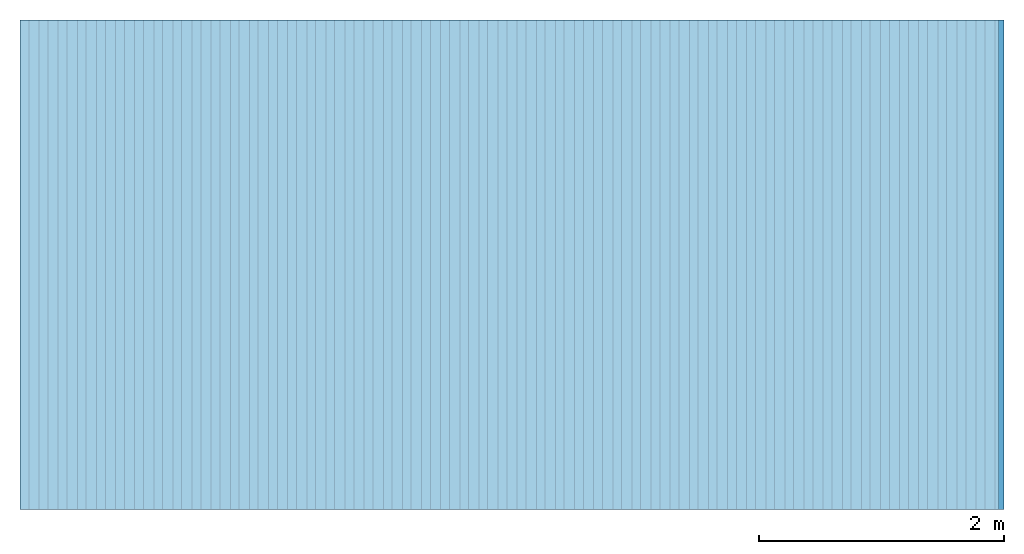
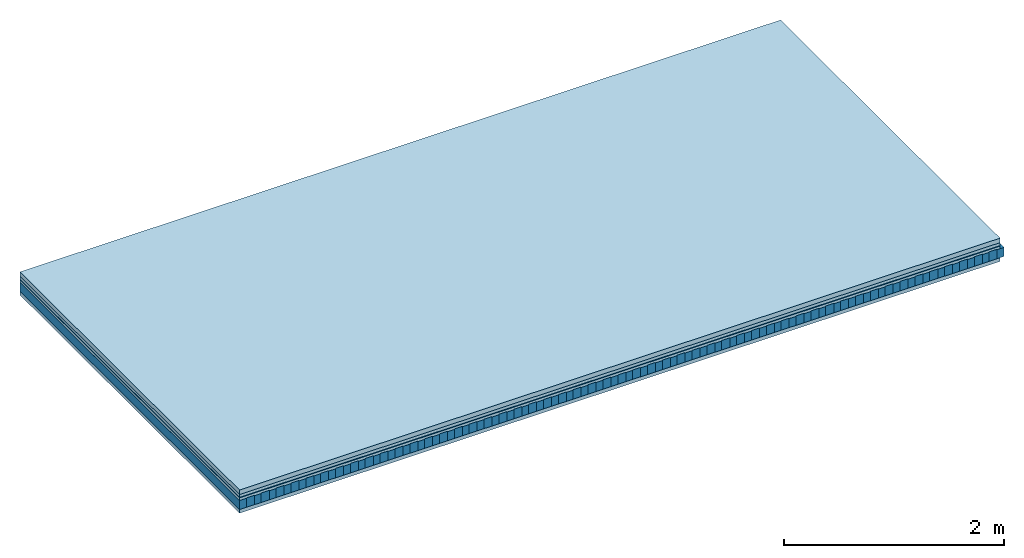
# One storey: 5 plates, 2 members, 1 element without a shape of its own.
"""IFC4 building model written with IfcOpenShell, lengths in metres."""

from ifc_helpers import new_model, si_unit, derived_unit, direction, frame, frame_2d, origin, origin_with_axes, place, context, project, spatial, rectangle, extrude, material, layer, layer_set, type_object, element, aggregate, save


model = new_model("IFC4")

# Units and contexts
plan_context = context("Plan", 3, precision=1e-05, world=origin(), true_north=direction((0.0, 1.0)))
model_context = context("Model", 3, precision=1e-05, world=origin(), true_north=direction((0.0, 1.0)))
ifc_project = project(units=[si_unit("LENGTHUNIT", "METRE"), derived_unit("SOUNDPRESSUREUNIT", [(si_unit("PRESSUREUNIT", "PASCAL", prefix="MICRO"), 0)]), si_unit("ENERGYUNIT", "JOULE", prefix="MEGA"), si_unit("MASSUNIT", "GRAM", prefix="KILO"), derived_unit("THERMALTRANSMITTANCEUNIT", [(si_unit("POWERUNIT", "WATT"), 1), (si_unit("AREAUNIT", "SQUARE_METRE"), -1), (si_unit("THERMODYNAMICTEMPERATUREUNIT", "KELVIN"), -1)]), derived_unit("AREADENSITYUNIT", [(si_unit("MASSUNIT", "GRAM", prefix="KILO"), 1), (si_unit("AREAUNIT", "SQUARE_METRE"), -1)]), derived_unit("USERDEFINED", [(si_unit("ENERGYUNIT", "JOULE", prefix="MEGA"), 1), (si_unit("AREAUNIT", "SQUARE_METRE"), -1)])], contexts=[plan_context, model_context])

# Site, building, storey
site = spatial("IfcSite", under=ifc_project)
building_placement = place(None, origin())
building = spatial("IfcBuilding", under=site, at=building_placement)
storey_placement = place(building_placement, origin())
storey = spatial("IfcBuildingStorey", under=building, at=storey_placement)

# Slab, members, plates
ifc_material_1 = material(Name="Cement screed", Category="04.006")
ifc_layer_1 = layer(ifc_material_1, 0.05, Name="On-material")
ifc_material_2 = material(Name="32/30mm", Category="10.009")
ifc_layer_2 = layer(ifc_material_2, 0.032, Name="Impact sound insulation")
ifc_material_3 = material(Name="Step 6mm", Category="10.009")
ifc_layer_3 = layer(ifc_material_3, 0.006, Name="Additional insulation")
ifc_material_4 = material()
ifc_layer_4 = layer(ifc_material_4, 0.03, Name="Sub-floor")
ifc_material_5 = material(Name="Rigid, of the art")
ifc_layer_5 = layer(ifc_material_5, 0.0, Name="Bond")
ifc_layer_6 = layer(None, 0.1, Name="Supporting structure")
ifc_layer_7 = layer(ifc_material_5, 0.0, Name="Bond")
ifc_material_6 = material(Name="panel on the underside HBF 40mm (20+20mm)", Category="07.001")
ifc_layer_8 = layer(ifc_material_6, 0.04, Name="Lower layer 1")
ifc_layer_set = layer_set([ifc_layer_1, ifc_layer_2, ifc_layer_3, ifc_layer_4, ifc_layer_5, ifc_layer_6, ifc_layer_7, ifc_layer_8])
slab_type = type_object("IfcSlabType", Name="A0084", PredefinedType="NOTDEFINED", material=ifc_layer_set)
slab_placement = place(None, frame((0.0, 0.0, 0.0), z_axis=(0.0, 0.0, -1.0), x_axis=(1.0, 0.0, 0.0)))
slab = element("IfcSlab", 1, at=slab_placement, inside=storey, type_object=slab_type, material=ifc_layer_set, Name="Slab #1")
ifc_material_7 = material(Name="Block Q4")
member_1_placement = place(slab_placement, origin())
member_1 = element("IfcMember", 2, at=member_1_placement, material=ifc_material_7, Name="Supporting structure", context=plan_context, shape_type="SweptSolid", body=[
    extrude(rectangle(XDim=0.071666666666667, YDim=0.1, at=frame_2d((0.0358333333333335, 0.05), x_axis=(1.0, 0.0))), frame((0.0, 4.0, 0.118), z_axis=(0.0, -1.0, 0.0), x_axis=(1.0, 0.0, 0.0)), (0.0, 0.0, 1.0), 4.0),
    extrude(rectangle(XDim=0.071666666666667, YDim=0.1, at=frame_2d((0.0358333333333335, 0.05), x_axis=(1.0, 0.0))), frame((0.15625, 4.0, 0.118), z_axis=(0.0, -1.0, 0.0), x_axis=(1.0, 0.0, 0.0)), (0.0, 0.0, 1.0), 4.0),
    extrude(rectangle(XDim=0.071666666666667, YDim=0.1, at=frame_2d((0.0358333333333335, 0.05), x_axis=(1.0, 0.0))), frame((0.3125, 4.0, 0.118), z_axis=(0.0, -1.0, 0.0), x_axis=(1.0, 0.0, 0.0)), (0.0, 0.0, 1.0), 4.0),
    extrude(rectangle(XDim=0.071666666666667, YDim=0.1, at=frame_2d((0.0358333333333335, 0.05), x_axis=(1.0, 0.0))), frame((0.46875, 4.0, 0.118), z_axis=(0.0, -1.0, 0.0), x_axis=(1.0, 0.0, 0.0)), (0.0, 0.0, 1.0), 4.0),
    extrude(rectangle(XDim=0.071666666666667, YDim=0.1, at=frame_2d((0.0358333333333335, 0.05), x_axis=(1.0, 0.0))), frame((0.625, 4.0, 0.118), z_axis=(0.0, -1.0, 0.0), x_axis=(1.0, 0.0, 0.0)), (0.0, 0.0, 1.0), 4.0),
    extrude(rectangle(XDim=0.071666666666667, YDim=0.1, at=frame_2d((0.0358333333333335, 0.05), x_axis=(1.0, 0.0))), frame((0.78125, 4.0, 0.118), z_axis=(0.0, -1.0, 0.0), x_axis=(1.0, 0.0, 0.0)), (0.0, 0.0, 1.0), 4.0),
    extrude(rectangle(XDim=0.071666666666667, YDim=0.1, at=frame_2d((0.0358333333333335, 0.05), x_axis=(1.0, 0.0))), frame((0.9375, 4.0, 0.118), z_axis=(0.0, -1.0, 0.0), x_axis=(1.0, 0.0, 0.0)), (0.0, 0.0, 1.0), 4.0),
    extrude(rectangle(XDim=0.071666666666667, YDim=0.1, at=frame_2d((0.0358333333333335, 0.05), x_axis=(1.0, 0.0))), frame((1.09375, 4.0, 0.118), z_axis=(0.0, -1.0, 0.0), x_axis=(1.0, 0.0, 0.0)), (0.0, 0.0, 1.0), 4.0),
    extrude(rectangle(XDim=0.071666666666667, YDim=0.1, at=frame_2d((0.0358333333333335, 0.05), x_axis=(1.0, 0.0))), frame((1.25, 4.0, 0.118), z_axis=(0.0, -1.0, 0.0), x_axis=(1.0, 0.0, 0.0)), (0.0, 0.0, 1.0), 4.0),
    extrude(rectangle(XDim=0.071666666666667, YDim=0.1, at=frame_2d((0.0358333333333335, 0.05), x_axis=(1.0, 0.0))), frame((1.40625, 4.0, 0.118), z_axis=(0.0, -1.0, 0.0), x_axis=(1.0, 0.0, 0.0)), (0.0, 0.0, 1.0), 4.0),
    extrude(rectangle(XDim=0.071666666666667, YDim=0.1, at=frame_2d((0.0358333333333335, 0.05), x_axis=(1.0, 0.0))), frame((1.5625, 4.0, 0.118), z_axis=(0.0, -1.0, 0.0), x_axis=(1.0, 0.0, 0.0)), (0.0, 0.0, 1.0), 4.0),
    extrude(rectangle(XDim=0.071666666666667, YDim=0.1, at=frame_2d((0.0358333333333335, 0.05), x_axis=(1.0, 0.0))), frame((1.71875, 4.0, 0.118), z_axis=(0.0, -1.0, 0.0), x_axis=(1.0, 0.0, 0.0)), (0.0, 0.0, 1.0), 4.0),
    extrude(rectangle(XDim=0.071666666666667, YDim=0.1, at=frame_2d((0.0358333333333335, 0.05), x_axis=(1.0, 0.0))), frame((1.875, 4.0, 0.118), z_axis=(0.0, -1.0, 0.0), x_axis=(1.0, 0.0, 0.0)), (0.0, 0.0, 1.0), 4.0),
    extrude(rectangle(XDim=0.071666666666667, YDim=0.1, at=frame_2d((0.0358333333333335, 0.05), x_axis=(1.0, 0.0))), frame((2.03125, 4.0, 0.118), z_axis=(0.0, -1.0, 0.0), x_axis=(1.0, 0.0, 0.0)), (0.0, 0.0, 1.0), 4.0),
    extrude(rectangle(XDim=0.071666666666667, YDim=0.1, at=frame_2d((0.0358333333333335, 0.05), x_axis=(1.0, 0.0))), frame((2.1875, 4.0, 0.118), z_axis=(0.0, -1.0, 0.0), x_axis=(1.0, 0.0, 0.0)), (0.0, 0.0, 1.0), 4.0),
    extrude(rectangle(XDim=0.071666666666667, YDim=0.1, at=frame_2d((0.0358333333333335, 0.05), x_axis=(1.0, 0.0))), frame((2.34375, 4.0, 0.118), z_axis=(0.0, -1.0, 0.0), x_axis=(1.0, 0.0, 0.0)), (0.0, 0.0, 1.0), 4.0),
    extrude(rectangle(XDim=0.071666666666667, YDim=0.1, at=frame_2d((0.0358333333333335, 0.05), x_axis=(1.0, 0.0))), frame((2.5, 4.0, 0.118), z_axis=(0.0, -1.0, 0.0), x_axis=(1.0, 0.0, 0.0)), (0.0, 0.0, 1.0), 4.0),
    extrude(rectangle(XDim=0.071666666666667, YDim=0.1, at=frame_2d((0.0358333333333335, 0.05), x_axis=(1.0, 0.0))), frame((2.65625, 4.0, 0.118), z_axis=(0.0, -1.0, 0.0), x_axis=(1.0, 0.0, 0.0)), (0.0, 0.0, 1.0), 4.0),
    extrude(rectangle(XDim=0.071666666666667, YDim=0.1, at=frame_2d((0.0358333333333335, 0.05), x_axis=(1.0, 0.0))), frame((2.8125, 4.0, 0.118), z_axis=(0.0, -1.0, 0.0), x_axis=(1.0, 0.0, 0.0)), (0.0, 0.0, 1.0), 4.0),
    extrude(rectangle(XDim=0.071666666666667, YDim=0.1, at=frame_2d((0.0358333333333335, 0.05), x_axis=(1.0, 0.0))), frame((2.96875, 4.0, 0.118), z_axis=(0.0, -1.0, 0.0), x_axis=(1.0, 0.0, 0.0)), (0.0, 0.0, 1.0), 4.0),
    extrude(rectangle(XDim=0.071666666666667, YDim=0.1, at=frame_2d((0.0358333333333335, 0.05), x_axis=(1.0, 0.0))), frame((3.125, 4.0, 0.118), z_axis=(0.0, -1.0, 0.0), x_axis=(1.0, 0.0, 0.0)), (0.0, 0.0, 1.0), 4.0),
    extrude(rectangle(XDim=0.071666666666667, YDim=0.1, at=frame_2d((0.0358333333333335, 0.05), x_axis=(1.0, 0.0))), frame((3.28125, 4.0, 0.118), z_axis=(0.0, -1.0, 0.0), x_axis=(1.0, 0.0, 0.0)), (0.0, 0.0, 1.0), 4.0),
    extrude(rectangle(XDim=0.071666666666667, YDim=0.1, at=frame_2d((0.0358333333333335, 0.05), x_axis=(1.0, 0.0))), frame((3.4375, 4.0, 0.118), z_axis=(0.0, -1.0, 0.0), x_axis=(1.0, 0.0, 0.0)), (0.0, 0.0, 1.0), 4.0),
    extrude(rectangle(XDim=0.071666666666667, YDim=0.1, at=frame_2d((0.0358333333333335, 0.05), x_axis=(1.0, 0.0))), frame((3.59375, 4.0, 0.118), z_axis=(0.0, -1.0, 0.0), x_axis=(1.0, 0.0, 0.0)), (0.0, 0.0, 1.0), 4.0),
    extrude(rectangle(XDim=0.071666666666667, YDim=0.1, at=frame_2d((0.0358333333333335, 0.05), x_axis=(1.0, 0.0))), frame((3.75, 4.0, 0.118), z_axis=(0.0, -1.0, 0.0), x_axis=(1.0, 0.0, 0.0)), (0.0, 0.0, 1.0), 4.0),
    extrude(rectangle(XDim=0.071666666666667, YDim=0.1, at=frame_2d((0.0358333333333335, 0.05), x_axis=(1.0, 0.0))), frame((3.90625, 4.0, 0.118), z_axis=(0.0, -1.0, 0.0), x_axis=(1.0, 0.0, 0.0)), (0.0, 0.0, 1.0), 4.0),
    extrude(rectangle(XDim=0.071666666666667, YDim=0.1, at=frame_2d((0.0358333333333335, 0.05), x_axis=(1.0, 0.0))), frame((4.0625, 4.0, 0.118), z_axis=(0.0, -1.0, 0.0), x_axis=(1.0, 0.0, 0.0)), (0.0, 0.0, 1.0), 4.0),
    extrude(rectangle(XDim=0.071666666666667, YDim=0.1, at=frame_2d((0.0358333333333335, 0.05), x_axis=(1.0, 0.0))), frame((4.21875, 4.0, 0.118), z_axis=(0.0, -1.0, 0.0), x_axis=(1.0, 0.0, 0.0)), (0.0, 0.0, 1.0), 4.0),
    extrude(rectangle(XDim=0.071666666666667, YDim=0.1, at=frame_2d((0.0358333333333335, 0.05), x_axis=(1.0, 0.0))), frame((4.375, 4.0, 0.118), z_axis=(0.0, -1.0, 0.0), x_axis=(1.0, 0.0, 0.0)), (0.0, 0.0, 1.0), 4.0),
    extrude(rectangle(XDim=0.071666666666667, YDim=0.1, at=frame_2d((0.0358333333333335, 0.05), x_axis=(1.0, 0.0))), frame((4.53125, 4.0, 0.118), z_axis=(0.0, -1.0, 0.0), x_axis=(1.0, 0.0, 0.0)), (0.0, 0.0, 1.0), 4.0),
    extrude(rectangle(XDim=0.071666666666667, YDim=0.1, at=frame_2d((0.0358333333333335, 0.05), x_axis=(1.0, 0.0))), frame((4.6875, 4.0, 0.118), z_axis=(0.0, -1.0, 0.0), x_axis=(1.0, 0.0, 0.0)), (0.0, 0.0, 1.0), 4.0),
    extrude(rectangle(XDim=0.071666666666667, YDim=0.1, at=frame_2d((0.0358333333333335, 0.05), x_axis=(1.0, 0.0))), frame((4.84375, 4.0, 0.118), z_axis=(0.0, -1.0, 0.0), x_axis=(1.0, 0.0, 0.0)), (0.0, 0.0, 1.0), 4.0),
    extrude(rectangle(XDim=0.071666666666667, YDim=0.1, at=frame_2d((0.0358333333333335, 0.05), x_axis=(1.0, 0.0))), frame((5.0, 4.0, 0.118), z_axis=(0.0, -1.0, 0.0), x_axis=(1.0, 0.0, 0.0)), (0.0, 0.0, 1.0), 4.0),
    extrude(rectangle(XDim=0.071666666666667, YDim=0.1, at=frame_2d((0.0358333333333335, 0.05), x_axis=(1.0, 0.0))), frame((5.15625, 4.0, 0.118), z_axis=(0.0, -1.0, 0.0), x_axis=(1.0, 0.0, 0.0)), (0.0, 0.0, 1.0), 4.0),
    extrude(rectangle(XDim=0.071666666666667, YDim=0.1, at=frame_2d((0.0358333333333335, 0.05), x_axis=(1.0, 0.0))), frame((5.3125, 4.0, 0.118), z_axis=(0.0, -1.0, 0.0), x_axis=(1.0, 0.0, 0.0)), (0.0, 0.0, 1.0), 4.0),
    extrude(rectangle(XDim=0.071666666666667, YDim=0.1, at=frame_2d((0.0358333333333335, 0.05), x_axis=(1.0, 0.0))), frame((5.46875, 4.0, 0.118), z_axis=(0.0, -1.0, 0.0), x_axis=(1.0, 0.0, 0.0)), (0.0, 0.0, 1.0), 4.0),
    extrude(rectangle(XDim=0.071666666666667, YDim=0.1, at=frame_2d((0.0358333333333335, 0.05), x_axis=(1.0, 0.0))), frame((5.625, 4.0, 0.118), z_axis=(0.0, -1.0, 0.0), x_axis=(1.0, 0.0, 0.0)), (0.0, 0.0, 1.0), 4.0),
    extrude(rectangle(XDim=0.071666666666667, YDim=0.1, at=frame_2d((0.0358333333333335, 0.05), x_axis=(1.0, 0.0))), frame((5.78125, 4.0, 0.118), z_axis=(0.0, -1.0, 0.0), x_axis=(1.0, 0.0, 0.0)), (0.0, 0.0, 1.0), 4.0),
    extrude(rectangle(XDim=0.071666666666667, YDim=0.1, at=frame_2d((0.0358333333333335, 0.05), x_axis=(1.0, 0.0))), frame((5.9375, 4.0, 0.118), z_axis=(0.0, -1.0, 0.0), x_axis=(1.0, 0.0, 0.0)), (0.0, 0.0, 1.0), 4.0),
    extrude(rectangle(XDim=0.071666666666667, YDim=0.1, at=frame_2d((0.0358333333333335, 0.05), x_axis=(1.0, 0.0))), frame((6.09375, 4.0, 0.118), z_axis=(0.0, -1.0, 0.0), x_axis=(1.0, 0.0, 0.0)), (0.0, 0.0, 1.0), 4.0),
    extrude(rectangle(XDim=0.071666666666667, YDim=0.1, at=frame_2d((0.0358333333333335, 0.05), x_axis=(1.0, 0.0))), frame((6.25, 4.0, 0.118), z_axis=(0.0, -1.0, 0.0), x_axis=(1.0, 0.0, 0.0)), (0.0, 0.0, 1.0), 4.0),
    extrude(rectangle(XDim=0.071666666666667, YDim=0.1, at=frame_2d((0.0358333333333335, 0.05), x_axis=(1.0, 0.0))), frame((6.40625, 4.0, 0.118), z_axis=(0.0, -1.0, 0.0), x_axis=(1.0, 0.0, 0.0)), (0.0, 0.0, 1.0), 4.0),
    extrude(rectangle(XDim=0.071666666666667, YDim=0.1, at=frame_2d((0.0358333333333335, 0.05), x_axis=(1.0, 0.0))), frame((6.5625, 4.0, 0.118), z_axis=(0.0, -1.0, 0.0), x_axis=(1.0, 0.0, 0.0)), (0.0, 0.0, 1.0), 4.0),
    extrude(rectangle(XDim=0.071666666666667, YDim=0.1, at=frame_2d((0.0358333333333335, 0.05), x_axis=(1.0, 0.0))), frame((6.71875, 4.0, 0.118), z_axis=(0.0, -1.0, 0.0), x_axis=(1.0, 0.0, 0.0)), (0.0, 0.0, 1.0), 4.0),
    extrude(rectangle(XDim=0.071666666666667, YDim=0.1, at=frame_2d((0.0358333333333335, 0.05), x_axis=(1.0, 0.0))), frame((6.875, 4.0, 0.118), z_axis=(0.0, -1.0, 0.0), x_axis=(1.0, 0.0, 0.0)), (0.0, 0.0, 1.0), 4.0),
    extrude(rectangle(XDim=0.071666666666667, YDim=0.1, at=frame_2d((0.0358333333333335, 0.05), x_axis=(1.0, 0.0))), frame((7.03125, 4.0, 0.118), z_axis=(0.0, -1.0, 0.0), x_axis=(1.0, 0.0, 0.0)), (0.0, 0.0, 1.0), 4.0),
    extrude(rectangle(XDim=0.071666666666667, YDim=0.1, at=frame_2d((0.0358333333333335, 0.05), x_axis=(1.0, 0.0))), frame((7.1875, 4.0, 0.118), z_axis=(0.0, -1.0, 0.0), x_axis=(1.0, 0.0, 0.0)), (0.0, 0.0, 1.0), 4.0),
    extrude(rectangle(XDim=0.071666666666667, YDim=0.1, at=frame_2d((0.0358333333333335, 0.05), x_axis=(1.0, 0.0))), frame((7.34375, 4.0, 0.118), z_axis=(0.0, -1.0, 0.0), x_axis=(1.0, 0.0, 0.0)), (0.0, 0.0, 1.0), 4.0),
    extrude(rectangle(XDim=0.071666666666667, YDim=0.1, at=frame_2d((0.0358333333333335, 0.05), x_axis=(1.0, 0.0))), frame((7.5, 4.0, 0.118), z_axis=(0.0, -1.0, 0.0), x_axis=(1.0, 0.0, 0.0)), (0.0, 0.0, 1.0), 4.0),
    extrude(rectangle(XDim=0.071666666666667, YDim=0.1, at=frame_2d((0.0358333333333335, 0.05), x_axis=(1.0, 0.0))), frame((7.65625, 4.0, 0.118), z_axis=(0.0, -1.0, 0.0), x_axis=(1.0, 0.0, 0.0)), (0.0, 0.0, 1.0), 4.0),
    extrude(rectangle(XDim=0.071666666666667, YDim=0.1, at=frame_2d((0.0358333333333335, 0.05), x_axis=(1.0, 0.0))), frame((7.8125, 4.0, 0.118), z_axis=(0.0, -1.0, 0.0), x_axis=(1.0, 0.0, 0.0)), (0.0, 0.0, 1.0), 4.0),
    extrude(rectangle(XDim=0.071666666666667, YDim=0.1, at=frame_2d((0.0358333333333335, 0.05), x_axis=(1.0, 0.0))), frame((7.96875, 4.0, 0.118), z_axis=(0.0, -1.0, 0.0), x_axis=(1.0, 0.0, 0.0)), (0.0, 0.0, 1.0), 4.0),
])
ifc_material_8 = material()
member_2_placement = place(slab_placement, origin())
member_2 = element("IfcMember", 3, at=member_2_placement, material=ifc_material_8, Name="in supporting structure", context=plan_context, shape_type="SweptSolid", body=[
    extrude(rectangle(XDim=0.084583333333333, YDim=0.105, at=frame_2d((0.0422916666666665, 0.0525), x_axis=(1.0, 0.0))), frame((0.071666666666667, 4.0, 0.113), z_axis=(0.0, -1.0, 0.0), x_axis=(1.0, 0.0, 0.0)), (0.0, 0.0, 1.0), 4.0),
    extrude(rectangle(XDim=0.084583333333333, YDim=0.105, at=frame_2d((0.0422916666666665, 0.0525), x_axis=(1.0, 0.0))), frame((0.227916666666667, 4.0, 0.113), z_axis=(0.0, -1.0, 0.0), x_axis=(1.0, 0.0, 0.0)), (0.0, 0.0, 1.0), 4.0),
    extrude(rectangle(XDim=0.084583333333333, YDim=0.105, at=frame_2d((0.0422916666666665, 0.0525), x_axis=(1.0, 0.0))), frame((0.384166666666667, 4.0, 0.113), z_axis=(0.0, -1.0, 0.0), x_axis=(1.0, 0.0, 0.0)), (0.0, 0.0, 1.0), 4.0),
    extrude(rectangle(XDim=0.084583333333333, YDim=0.105, at=frame_2d((0.0422916666666665, 0.0525), x_axis=(1.0, 0.0))), frame((0.540416666666667, 4.0, 0.113), z_axis=(0.0, -1.0, 0.0), x_axis=(1.0, 0.0, 0.0)), (0.0, 0.0, 1.0), 4.0),
    extrude(rectangle(XDim=0.084583333333333, YDim=0.105, at=frame_2d((0.0422916666666665, 0.0525), x_axis=(1.0, 0.0))), frame((0.696666666666667, 4.0, 0.113), z_axis=(0.0, -1.0, 0.0), x_axis=(1.0, 0.0, 0.0)), (0.0, 0.0, 1.0), 4.0),
    extrude(rectangle(XDim=0.084583333333333, YDim=0.105, at=frame_2d((0.0422916666666665, 0.0525), x_axis=(1.0, 0.0))), frame((0.852916666666667, 4.0, 0.113), z_axis=(0.0, -1.0, 0.0), x_axis=(1.0, 0.0, 0.0)), (0.0, 0.0, 1.0), 4.0),
    extrude(rectangle(XDim=0.084583333333333, YDim=0.105, at=frame_2d((0.0422916666666665, 0.0525), x_axis=(1.0, 0.0))), frame((1.00916666666667, 4.0, 0.113), z_axis=(0.0, -1.0, 0.0), x_axis=(1.0, 0.0, 0.0)), (0.0, 0.0, 1.0), 4.0),
    extrude(rectangle(XDim=0.084583333333333, YDim=0.105, at=frame_2d((0.0422916666666665, 0.0525), x_axis=(1.0, 0.0))), frame((1.16541666666667, 4.0, 0.113), z_axis=(0.0, -1.0, 0.0), x_axis=(1.0, 0.0, 0.0)), (0.0, 0.0, 1.0), 4.0),
    extrude(rectangle(XDim=0.084583333333333, YDim=0.105, at=frame_2d((0.0422916666666665, 0.0525), x_axis=(1.0, 0.0))), frame((1.32166666666667, 4.0, 0.113), z_axis=(0.0, -1.0, 0.0), x_axis=(1.0, 0.0, 0.0)), (0.0, 0.0, 1.0), 4.0),
    extrude(rectangle(XDim=0.084583333333333, YDim=0.105, at=frame_2d((0.0422916666666665, 0.0525), x_axis=(1.0, 0.0))), frame((1.47791666666667, 4.0, 0.113), z_axis=(0.0, -1.0, 0.0), x_axis=(1.0, 0.0, 0.0)), (0.0, 0.0, 1.0), 4.0),
    extrude(rectangle(XDim=0.084583333333333, YDim=0.105, at=frame_2d((0.0422916666666665, 0.0525), x_axis=(1.0, 0.0))), frame((1.63416666666667, 4.0, 0.113), z_axis=(0.0, -1.0, 0.0), x_axis=(1.0, 0.0, 0.0)), (0.0, 0.0, 1.0), 4.0),
    extrude(rectangle(XDim=0.084583333333333, YDim=0.105, at=frame_2d((0.0422916666666665, 0.0525), x_axis=(1.0, 0.0))), frame((1.79041666666667, 4.0, 0.113), z_axis=(0.0, -1.0, 0.0), x_axis=(1.0, 0.0, 0.0)), (0.0, 0.0, 1.0), 4.0),
    extrude(rectangle(XDim=0.084583333333333, YDim=0.105, at=frame_2d((0.0422916666666665, 0.0525), x_axis=(1.0, 0.0))), frame((1.94666666666667, 4.0, 0.113), z_axis=(0.0, -1.0, 0.0), x_axis=(1.0, 0.0, 0.0)), (0.0, 0.0, 1.0), 4.0),
    extrude(rectangle(XDim=0.084583333333333, YDim=0.105, at=frame_2d((0.0422916666666665, 0.0525), x_axis=(1.0, 0.0))), frame((2.10291666666667, 4.0, 0.113), z_axis=(0.0, -1.0, 0.0), x_axis=(1.0, 0.0, 0.0)), (0.0, 0.0, 1.0), 4.0),
    extrude(rectangle(XDim=0.084583333333333, YDim=0.105, at=frame_2d((0.0422916666666665, 0.0525), x_axis=(1.0, 0.0))), frame((2.25916666666667, 4.0, 0.113), z_axis=(0.0, -1.0, 0.0), x_axis=(1.0, 0.0, 0.0)), (0.0, 0.0, 1.0), 4.0),
    extrude(rectangle(XDim=0.084583333333333, YDim=0.105, at=frame_2d((0.0422916666666665, 0.0525), x_axis=(1.0, 0.0))), frame((2.41541666666667, 4.0, 0.113), z_axis=(0.0, -1.0, 0.0), x_axis=(1.0, 0.0, 0.0)), (0.0, 0.0, 1.0), 4.0),
    extrude(rectangle(XDim=0.084583333333333, YDim=0.105, at=frame_2d((0.0422916666666665, 0.0525), x_axis=(1.0, 0.0))), frame((2.57166666666667, 4.0, 0.113), z_axis=(0.0, -1.0, 0.0), x_axis=(1.0, 0.0, 0.0)), (0.0, 0.0, 1.0), 4.0),
    extrude(rectangle(XDim=0.084583333333333, YDim=0.105, at=frame_2d((0.0422916666666665, 0.0525), x_axis=(1.0, 0.0))), frame((2.72791666666667, 4.0, 0.113), z_axis=(0.0, -1.0, 0.0), x_axis=(1.0, 0.0, 0.0)), (0.0, 0.0, 1.0), 4.0),
    extrude(rectangle(XDim=0.084583333333333, YDim=0.105, at=frame_2d((0.0422916666666665, 0.0525), x_axis=(1.0, 0.0))), frame((2.88416666666667, 4.0, 0.113), z_axis=(0.0, -1.0, 0.0), x_axis=(1.0, 0.0, 0.0)), (0.0, 0.0, 1.0), 4.0),
    extrude(rectangle(XDim=0.084583333333333, YDim=0.105, at=frame_2d((0.0422916666666665, 0.0525), x_axis=(1.0, 0.0))), frame((3.04041666666667, 4.0, 0.113), z_axis=(0.0, -1.0, 0.0), x_axis=(1.0, 0.0, 0.0)), (0.0, 0.0, 1.0), 4.0),
    extrude(rectangle(XDim=0.084583333333333, YDim=0.105, at=frame_2d((0.0422916666666665, 0.0525), x_axis=(1.0, 0.0))), frame((3.19666666666667, 4.0, 0.113), z_axis=(0.0, -1.0, 0.0), x_axis=(1.0, 0.0, 0.0)), (0.0, 0.0, 1.0), 4.0),
    extrude(rectangle(XDim=0.084583333333333, YDim=0.105, at=frame_2d((0.0422916666666665, 0.0525), x_axis=(1.0, 0.0))), frame((3.35291666666667, 4.0, 0.113), z_axis=(0.0, -1.0, 0.0), x_axis=(1.0, 0.0, 0.0)), (0.0, 0.0, 1.0), 4.0),
    extrude(rectangle(XDim=0.084583333333333, YDim=0.105, at=frame_2d((0.0422916666666665, 0.0525), x_axis=(1.0, 0.0))), frame((3.50916666666667, 4.0, 0.113), z_axis=(0.0, -1.0, 0.0), x_axis=(1.0, 0.0, 0.0)), (0.0, 0.0, 1.0), 4.0),
    extrude(rectangle(XDim=0.084583333333333, YDim=0.105, at=frame_2d((0.0422916666666665, 0.0525), x_axis=(1.0, 0.0))), frame((3.66541666666667, 4.0, 0.113), z_axis=(0.0, -1.0, 0.0), x_axis=(1.0, 0.0, 0.0)), (0.0, 0.0, 1.0), 4.0),
    extrude(rectangle(XDim=0.084583333333333, YDim=0.105, at=frame_2d((0.0422916666666665, 0.0525), x_axis=(1.0, 0.0))), frame((3.82166666666667, 4.0, 0.113), z_axis=(0.0, -1.0, 0.0), x_axis=(1.0, 0.0, 0.0)), (0.0, 0.0, 1.0), 4.0),
    extrude(rectangle(XDim=0.084583333333333, YDim=0.105, at=frame_2d((0.0422916666666665, 0.0525), x_axis=(1.0, 0.0))), frame((3.97791666666667, 4.0, 0.113), z_axis=(0.0, -1.0, 0.0), x_axis=(1.0, 0.0, 0.0)), (0.0, 0.0, 1.0), 4.0),
    extrude(rectangle(XDim=0.084583333333333, YDim=0.105, at=frame_2d((0.0422916666666665, 0.0525), x_axis=(1.0, 0.0))), frame((4.13416666666667, 4.0, 0.113), z_axis=(0.0, -1.0, 0.0), x_axis=(1.0, 0.0, 0.0)), (0.0, 0.0, 1.0), 4.0),
    extrude(rectangle(XDim=0.084583333333333, YDim=0.105, at=frame_2d((0.0422916666666665, 0.0525), x_axis=(1.0, 0.0))), frame((4.29041666666667, 4.0, 0.113), z_axis=(0.0, -1.0, 0.0), x_axis=(1.0, 0.0, 0.0)), (0.0, 0.0, 1.0), 4.0),
    extrude(rectangle(XDim=0.084583333333333, YDim=0.105, at=frame_2d((0.0422916666666665, 0.0525), x_axis=(1.0, 0.0))), frame((4.44666666666667, 4.0, 0.113), z_axis=(0.0, -1.0, 0.0), x_axis=(1.0, 0.0, 0.0)), (0.0, 0.0, 1.0), 4.0),
    extrude(rectangle(XDim=0.084583333333333, YDim=0.105, at=frame_2d((0.0422916666666665, 0.0525), x_axis=(1.0, 0.0))), frame((4.60291666666667, 4.0, 0.113), z_axis=(0.0, -1.0, 0.0), x_axis=(1.0, 0.0, 0.0)), (0.0, 0.0, 1.0), 4.0),
    extrude(rectangle(XDim=0.084583333333333, YDim=0.105, at=frame_2d((0.0422916666666665, 0.0525), x_axis=(1.0, 0.0))), frame((4.75916666666667, 4.0, 0.113), z_axis=(0.0, -1.0, 0.0), x_axis=(1.0, 0.0, 0.0)), (0.0, 0.0, 1.0), 4.0),
    extrude(rectangle(XDim=0.084583333333333, YDim=0.105, at=frame_2d((0.0422916666666665, 0.0525), x_axis=(1.0, 0.0))), frame((4.91541666666667, 4.0, 0.113), z_axis=(0.0, -1.0, 0.0), x_axis=(1.0, 0.0, 0.0)), (0.0, 0.0, 1.0), 4.0),
    extrude(rectangle(XDim=0.084583333333333, YDim=0.105, at=frame_2d((0.0422916666666665, 0.0525), x_axis=(1.0, 0.0))), frame((5.07166666666667, 4.0, 0.113), z_axis=(0.0, -1.0, 0.0), x_axis=(1.0, 0.0, 0.0)), (0.0, 0.0, 1.0), 4.0),
    extrude(rectangle(XDim=0.084583333333333, YDim=0.105, at=frame_2d((0.0422916666666665, 0.0525), x_axis=(1.0, 0.0))), frame((5.22791666666667, 4.0, 0.113), z_axis=(0.0, -1.0, 0.0), x_axis=(1.0, 0.0, 0.0)), (0.0, 0.0, 1.0), 4.0),
    extrude(rectangle(XDim=0.084583333333333, YDim=0.105, at=frame_2d((0.0422916666666665, 0.0525), x_axis=(1.0, 0.0))), frame((5.38416666666667, 4.0, 0.113), z_axis=(0.0, -1.0, 0.0), x_axis=(1.0, 0.0, 0.0)), (0.0, 0.0, 1.0), 4.0),
    extrude(rectangle(XDim=0.084583333333333, YDim=0.105, at=frame_2d((0.0422916666666665, 0.0525), x_axis=(1.0, 0.0))), frame((5.54041666666667, 4.0, 0.113), z_axis=(0.0, -1.0, 0.0), x_axis=(1.0, 0.0, 0.0)), (0.0, 0.0, 1.0), 4.0),
    extrude(rectangle(XDim=0.084583333333333, YDim=0.105, at=frame_2d((0.0422916666666665, 0.0525), x_axis=(1.0, 0.0))), frame((5.69666666666667, 4.0, 0.113), z_axis=(0.0, -1.0, 0.0), x_axis=(1.0, 0.0, 0.0)), (0.0, 0.0, 1.0), 4.0),
    extrude(rectangle(XDim=0.084583333333333, YDim=0.105, at=frame_2d((0.0422916666666665, 0.0525), x_axis=(1.0, 0.0))), frame((5.85291666666667, 4.0, 0.113), z_axis=(0.0, -1.0, 0.0), x_axis=(1.0, 0.0, 0.0)), (0.0, 0.0, 1.0), 4.0),
    extrude(rectangle(XDim=0.084583333333333, YDim=0.105, at=frame_2d((0.0422916666666665, 0.0525), x_axis=(1.0, 0.0))), frame((6.00916666666667, 4.0, 0.113), z_axis=(0.0, -1.0, 0.0), x_axis=(1.0, 0.0, 0.0)), (0.0, 0.0, 1.0), 4.0),
    extrude(rectangle(XDim=0.084583333333333, YDim=0.105, at=frame_2d((0.0422916666666665, 0.0525), x_axis=(1.0, 0.0))), frame((6.16541666666667, 4.0, 0.113), z_axis=(0.0, -1.0, 0.0), x_axis=(1.0, 0.0, 0.0)), (0.0, 0.0, 1.0), 4.0),
    extrude(rectangle(XDim=0.084583333333333, YDim=0.105, at=frame_2d((0.0422916666666665, 0.0525), x_axis=(1.0, 0.0))), frame((6.32166666666667, 4.0, 0.113), z_axis=(0.0, -1.0, 0.0), x_axis=(1.0, 0.0, 0.0)), (0.0, 0.0, 1.0), 4.0),
    extrude(rectangle(XDim=0.084583333333333, YDim=0.105, at=frame_2d((0.0422916666666665, 0.0525), x_axis=(1.0, 0.0))), frame((6.47791666666667, 4.0, 0.113), z_axis=(0.0, -1.0, 0.0), x_axis=(1.0, 0.0, 0.0)), (0.0, 0.0, 1.0), 4.0),
    extrude(rectangle(XDim=0.084583333333333, YDim=0.105, at=frame_2d((0.0422916666666665, 0.0525), x_axis=(1.0, 0.0))), frame((6.63416666666667, 4.0, 0.113), z_axis=(0.0, -1.0, 0.0), x_axis=(1.0, 0.0, 0.0)), (0.0, 0.0, 1.0), 4.0),
    extrude(rectangle(XDim=0.084583333333333, YDim=0.105, at=frame_2d((0.0422916666666665, 0.0525), x_axis=(1.0, 0.0))), frame((6.79041666666667, 4.0, 0.113), z_axis=(0.0, -1.0, 0.0), x_axis=(1.0, 0.0, 0.0)), (0.0, 0.0, 1.0), 4.0),
    extrude(rectangle(XDim=0.084583333333333, YDim=0.105, at=frame_2d((0.0422916666666665, 0.0525), x_axis=(1.0, 0.0))), frame((6.94666666666667, 4.0, 0.113), z_axis=(0.0, -1.0, 0.0), x_axis=(1.0, 0.0, 0.0)), (0.0, 0.0, 1.0), 4.0),
    extrude(rectangle(XDim=0.084583333333333, YDim=0.105, at=frame_2d((0.0422916666666665, 0.0525), x_axis=(1.0, 0.0))), frame((7.10291666666667, 4.0, 0.113), z_axis=(0.0, -1.0, 0.0), x_axis=(1.0, 0.0, 0.0)), (0.0, 0.0, 1.0), 4.0),
    extrude(rectangle(XDim=0.084583333333333, YDim=0.105, at=frame_2d((0.0422916666666665, 0.0525), x_axis=(1.0, 0.0))), frame((7.25916666666667, 4.0, 0.113), z_axis=(0.0, -1.0, 0.0), x_axis=(1.0, 0.0, 0.0)), (0.0, 0.0, 1.0), 4.0),
    extrude(rectangle(XDim=0.084583333333333, YDim=0.105, at=frame_2d((0.0422916666666665, 0.0525), x_axis=(1.0, 0.0))), frame((7.41541666666667, 4.0, 0.113), z_axis=(0.0, -1.0, 0.0), x_axis=(1.0, 0.0, 0.0)), (0.0, 0.0, 1.0), 4.0),
    extrude(rectangle(XDim=0.084583333333333, YDim=0.105, at=frame_2d((0.0422916666666665, 0.0525), x_axis=(1.0, 0.0))), frame((7.57166666666667, 4.0, 0.113), z_axis=(0.0, -1.0, 0.0), x_axis=(1.0, 0.0, 0.0)), (0.0, 0.0, 1.0), 4.0),
    extrude(rectangle(XDim=0.084583333333333, YDim=0.105, at=frame_2d((0.0422916666666665, 0.0525), x_axis=(1.0, 0.0))), frame((7.72791666666667, 4.0, 0.113), z_axis=(0.0, -1.0, 0.0), x_axis=(1.0, 0.0, 0.0)), (0.0, 0.0, 1.0), 4.0),
    extrude(rectangle(XDim=0.084583333333333, YDim=0.105, at=frame_2d((0.0422916666666665, 0.0525), x_axis=(1.0, 0.0))), frame((7.88416666666667, 4.0, 0.113), z_axis=(0.0, -1.0, 0.0), x_axis=(1.0, 0.0, 0.0)), (0.0, 0.0, 1.0), 4.0),
])
plate_1_placement = place(slab_placement, origin())
plate_1 = element("IfcPlate", 4, at=plate_1_placement, material=ifc_material_1, Name="On-material", context=plan_context, shape_type="SweptSolid", body=[
    extrude(rectangle(XDim=8.0, YDim=4.0, at=frame_2d((4.0, 2.0), x_axis=(1.0, 0.0))), origin_with_axes(), (0.0, 0.0, 1.0), 0.05),
])
plate_2_placement = place(slab_placement, origin())
plate_2 = element("IfcPlate", 5, at=plate_2_placement, material=ifc_material_2, Name="Impact sound insulation", context=plan_context, shape_type="SweptSolid", body=[
    extrude(rectangle(XDim=8.0, YDim=4.0, at=frame_2d((4.0, 2.0), x_axis=(1.0, 0.0))), frame((0.0, 0.0, 0.05), z_axis=(0.0, 0.0, 1.0), x_axis=(1.0, 0.0, 0.0)), (0.0, 0.0, 1.0), 0.032),
])
plate_3_placement = place(slab_placement, origin())
plate_3 = element("IfcPlate", 6, at=plate_3_placement, material=ifc_material_3, Name="Additional insulation", context=plan_context, shape_type="SweptSolid", body=[
    extrude(rectangle(XDim=8.0, YDim=4.0, at=frame_2d((4.0, 2.0), x_axis=(1.0, 0.0))), frame((0.0, 0.0, 0.082), z_axis=(0.0, 0.0, 1.0), x_axis=(1.0, 0.0, 0.0)), (0.0, 0.0, 1.0), 0.006),
])
plate_4_placement = place(slab_placement, origin())
plate_4 = element("IfcPlate", 7, at=plate_4_placement, material=ifc_material_4, Name="Sub-floor", context=plan_context, shape_type="SweptSolid", body=[
    extrude(rectangle(XDim=8.0, YDim=4.0, at=frame_2d((4.0, 2.0), x_axis=(1.0, 0.0))), frame((0.0, 0.0, 0.088), z_axis=(0.0, 0.0, 1.0), x_axis=(1.0, 0.0, 0.0)), (0.0, 0.0, 1.0), 0.03),
])
plate_5_placement = place(slab_placement, origin())
plate_5 = element("IfcPlate", 8, at=plate_5_placement, material=ifc_material_6, Name="Lower layer 1", context=plan_context, shape_type="SweptSolid", body=[
    extrude(rectangle(XDim=8.0, YDim=4.0, at=frame_2d((4.0, 2.0), x_axis=(1.0, 0.0))), frame((0.0, 0.0, 0.218), z_axis=(0.0, 0.0, 1.0), x_axis=(1.0, 0.0, 0.0)), (0.0, 0.0, 1.0), 0.04),
])
aggregate(slab, [plate_1, plate_2, plate_3, plate_4, member_1, member_2, plate_5])

save(model, "model.ifc")
